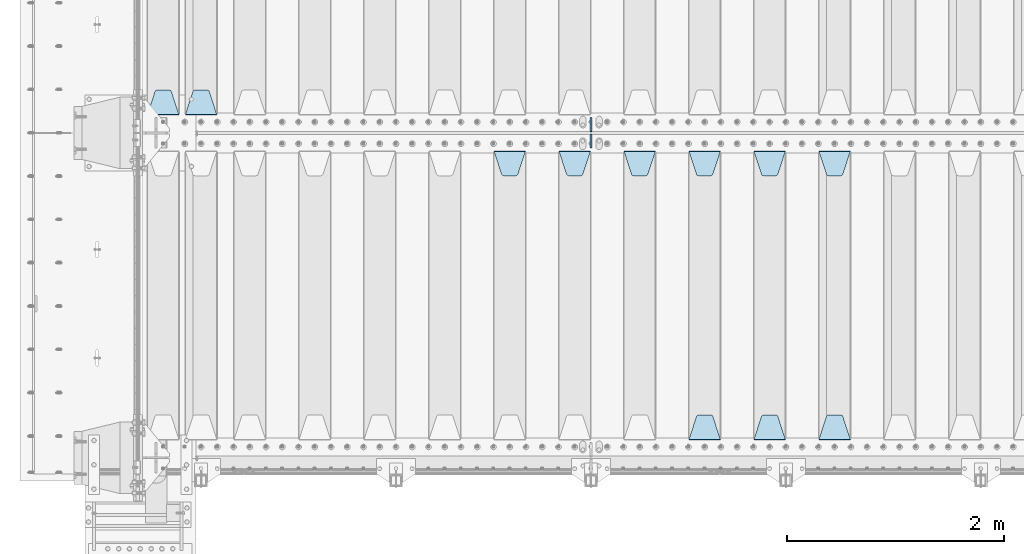
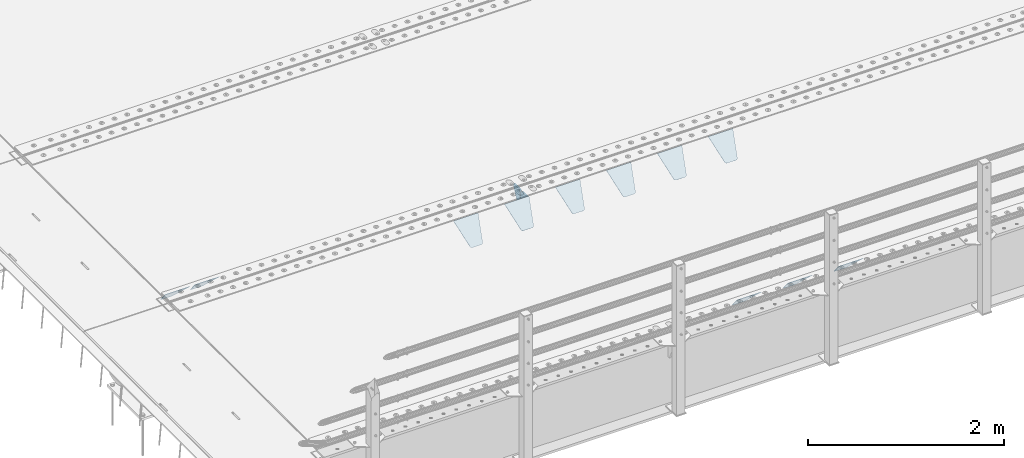
# One storey, part 193 of 240: 13 plates.
"""IFC2X3 building model written with IfcOpenShell, lengths in millimetres."""

from ifc_helpers import new_model, si_unit, frame, origin_with_axes, place, context, subcontext, project, spatial, faceted_brep, material, type_object, element, save


model = new_model("IFC2X3")

# Units and contexts
model_context = context("Model", 3, precision=1e-05, world=origin_with_axes())
body_context = subcontext(model_context, "Body", "Model", "MODEL_VIEW")
ifc_project = project(units=[si_unit("LENGTHUNIT", "METRE", prefix="MILLI"), si_unit("AREAUNIT", "SQUARE_METRE"), si_unit("VOLUMEUNIT", "CUBIC_METRE"), si_unit("MASSUNIT", "GRAM", prefix="KILO"), si_unit("TIMEUNIT", "SECOND"), si_unit("PLANEANGLEUNIT", "RADIAN"), si_unit("SOLIDANGLEUNIT", "STERADIAN"), si_unit("THERMODYNAMICTEMPERATUREUNIT", "DEGREE_CELSIUS"), si_unit("LUMINOUSINTENSITYUNIT", "LUMEN")], contexts=[model_context])

# Site, building, storey
site_placement = place(None, origin_with_axes())
site = spatial("IfcSite", under=ifc_project, at=site_placement, CompositionType="ELEMENT")
building_placement = place(site_placement, origin_with_axes())
building = spatial("IfcBuilding", under=site, at=building_placement, Name="Standard", CompositionType="ELEMENT")
storey_placement = place(building_placement, origin_with_axes())
storey = spatial("IfcBuildingStorey", under=building, at=storey_placement, Name="Undefined", CompositionType="ELEMENT", Elevation=0.0)

# Plates
ifc_material = material(Name="STEEL/S355N")
plate_type_1 = type_object("IfcPlateType", PredefinedType="NOTDEFINED")
plate_1_placement = place(storey_placement, frame((43145.0, 27168.232233047, -1.76776695296758), z_axis=(0.0, 0.707106781186547, -0.707106781186548), x_axis=(-1.0, 0.0, 0.0)))
element("IfcPlate", 1, at=plate_1_placement, inside=storey, type_object=plate_type_1, material=ifc_material, context=body_context, shape_type="Brep", body=[
    faceted_brep([(0.0, -2.5, 0.0), (69.345504679477, -2.50000000000364, 300.171731424827), (69.345504679477, 2.49999999999636, 300.171731424827), (0.0, 2.5, 0.0), (70.927406119954, -2.50000000000364, 304.897442415397), (70.927406119954, 2.49999999999636, 304.897442415397), (73.3818627772271, -2.50000000000728, 309.234538108525), (73.3818627772271, 2.49999999999636, 309.234538108529), (76.6187032999587, -2.50000000000728, 313.023683126099), (76.6187032999587, 2.49999999999636, 313.023683126103), (80.5190132705029, -2.50000000000364, 316.125672595368), (80.5190132705029, 2.49999999999636, 316.125672595368), (84.9395038596849, -2.50000000000364, 318.426546230472), (84.9395038596849, 2.49999999999636, 318.426546230472), (89.7177759439219, -2.5, 319.841774983277), (89.7177759439219, 2.49999999999636, 319.841774983273), (94.6782862926484, -2.50000000000364, 320.319366455074), (94.6782862926484, 2.49999999999636, 320.319366455074), (195.321713707352, -2.50000000000364, 320.319366455074), (195.321713707352, 2.49999999999636, 320.319366455074), (200.282224056078, -2.50000000000364, 319.841774983273), (200.282224056078, 2.49999999999636, 319.841774983273), (205.060496140315, -2.50000000000364, 318.426546230472), (205.060496140315, 2.49999999999636, 318.426546230472), (209.480986729497, -2.50000000000364, 316.125672595368), (209.480986729497, 2.49999999999636, 316.125672595368), (213.381296700041, -2.50000000000728, 313.023683126099), (213.381296700041, 2.49999999999272, 313.023683126099), (216.618137222766, -2.50000000000364, 309.234538108522), (216.618137222766, 2.49999999999636, 309.234538108522), (219.072593880039, -2.50000000000364, 304.897442415397), (219.072593880039, 2.49999999999636, 304.897442415397), (220.654495320523, -2.50000000000364, 300.171731424827), (220.654495320523, 2.49999999999636, 300.171731424827), (290.0, -2.50000000000364, -3.63797880709171e-12), (290.0, 2.49999999999636, -3.63797880709171e-12)], [[[0, 1, 2, 3]], [[1, 4, 5, 2]], [[4, 6, 7, 5]], [[6, 8, 9, 7]], [[8, 10, 11, 9]], [[10, 12, 13, 11]], [[12, 14, 15, 13]], [[14, 16, 17, 15]], [[16, 18, 19, 17]], [[18, 20, 21, 19]], [[20, 22, 23, 21]], [[22, 24, 25, 23]], [[24, 26, 27, 25]], [[26, 28, 29, 27]], [[28, 30, 31, 29]], [[30, 32, 33, 31]], [[32, 34, 35, 33]], [[34, 0, 3, 35]], [[5, 7, 9, 11, 13, 15, 17, 19, 21, 23, 25, 27, 29, 31, 33, 35, 3, 2]], [[34, 32, 30, 28, 26, 24, 22, 20, 18, 16, 14, 12, 10, 8, 6, 4, 1, 0]]]),
])
plate_2_placement = place(storey_placement, frame((48705.0, 26831.767766956, -1.76776695296758), z_axis=(0.0, -0.707106781186547, -0.707106781186548), x_axis=(1.0, 0.0, 0.0)))
element("IfcPlate", 2, at=plate_2_placement, inside=storey, type_object=plate_type_1, material=ifc_material, context=body_context, shape_type="Brep", body=[
    faceted_brep([(0.0, -2.5, 0.0), (69.345504679477, -2.50000000000364, 300.171731424827), (69.345504679477, 2.49999999999636, 300.171731424827), (0.0, 2.5, 0.0), (70.927406119954, -2.50000000000364, 304.897442415397), (70.927406119954, 2.49999999999636, 304.897442415397), (73.3818627772271, -2.50000000000728, 309.234538108525), (73.3818627772271, 2.49999999999636, 309.234538108529), (76.6187032999587, -2.50000000000728, 313.023683126099), (76.6187032999587, 2.49999999999636, 313.023683126103), (80.5190132705029, -2.50000000000364, 316.125672595368), (80.5190132705029, 2.49999999999636, 316.125672595368), (84.9395038596849, -2.50000000000364, 318.426546230472), (84.9395038596849, 2.49999999999636, 318.426546230472), (89.7177759439219, -2.5, 319.841774983277), (89.7177759439219, 2.49999999999636, 319.841774983273), (94.6782862926484, -2.50000000000364, 320.319366455074), (94.6782862926484, 2.49999999999636, 320.319366455074), (195.321713707352, -2.50000000000364, 320.319366455074), (195.321713707352, 2.49999999999636, 320.319366455074), (200.282224056078, -2.50000000000364, 319.841774983273), (200.282224056078, 2.49999999999636, 319.841774983273), (205.060496140315, -2.50000000000364, 318.426546230472), (205.060496140315, 2.49999999999636, 318.426546230472), (209.480986729497, -2.50000000000364, 316.125672595368), (209.480986729497, 2.49999999999636, 316.125672595368), (213.381296700041, -2.50000000000728, 313.023683126099), (213.381296700041, 2.49999999999272, 313.023683126099), (216.618137222766, -2.50000000000364, 309.234538108522), (216.618137222766, 2.49999999999636, 309.234538108522), (219.072593880039, -2.50000000000364, 304.897442415397), (219.072593880039, 2.49999999999636, 304.897442415397), (220.654495320523, -2.50000000000364, 300.171731424827), (220.654495320523, 2.49999999999636, 300.171731424827), (290.0, -2.50000000000364, -3.63797880709171e-12), (290.0, 2.49999999999636, -3.63797880709171e-12)], [[[0, 1, 2, 3]], [[1, 4, 5, 2]], [[4, 6, 7, 5]], [[6, 8, 9, 7]], [[8, 10, 11, 9]], [[10, 12, 13, 11]], [[12, 14, 15, 13]], [[14, 16, 17, 15]], [[16, 18, 19, 17]], [[18, 20, 21, 19]], [[20, 22, 23, 21]], [[22, 24, 25, 23]], [[24, 26, 27, 25]], [[26, 28, 29, 27]], [[28, 30, 31, 29]], [[30, 32, 33, 31]], [[32, 34, 35, 33]], [[34, 0, 3, 35]], [[5, 7, 9, 11, 13, 15, 17, 19, 21, 23, 25, 27, 29, 31, 33, 35, 3, 2]], [[34, 32, 30, 28, 26, 24, 22, 20, 18, 16, 14, 12, 10, 8, 6, 4, 1, 0]]]),
])
plate_3_placement = place(storey_placement, frame((48995.0, 24168.232233047, -1.76776695296758), z_axis=(0.0, 0.707106781186547, -0.707106781186548), x_axis=(-1.0, 0.0, 0.0)))
element("IfcPlate", 3, at=plate_3_placement, inside=storey, type_object=plate_type_1, material=ifc_material, context=body_context, shape_type="Brep", body=[
    faceted_brep([(0.0, -2.5, 0.0), (69.345504679477, -2.50000000000364, 300.171731424827), (69.345504679477, 2.49999999999636, 300.171731424827), (0.0, 2.5, 0.0), (70.927406119954, -2.50000000000364, 304.897442415397), (70.927406119954, 2.49999999999636, 304.897442415397), (73.3818627772271, -2.50000000000728, 309.234538108525), (73.3818627772271, 2.49999999999636, 309.234538108529), (76.6187032999587, -2.50000000000728, 313.023683126099), (76.6187032999587, 2.49999999999636, 313.023683126103), (80.5190132705029, -2.50000000000364, 316.125672595368), (80.5190132705029, 2.49999999999636, 316.125672595368), (84.9395038596849, -2.50000000000364, 318.426546230472), (84.9395038596849, 2.49999999999636, 318.426546230472), (89.7177759439219, -2.5, 319.841774983277), (89.7177759439219, 2.49999999999636, 319.841774983273), (94.6782862926484, -2.50000000000364, 320.319366455074), (94.6782862926484, 2.49999999999636, 320.319366455074), (195.321713707352, -2.50000000000364, 320.319366455074), (195.321713707352, 2.49999999999636, 320.319366455074), (200.282224056078, -2.50000000000364, 319.841774983273), (200.282224056078, 2.49999999999636, 319.841774983273), (205.060496140315, -2.50000000000364, 318.426546230472), (205.060496140315, 2.49999999999636, 318.426546230472), (209.480986729497, -2.50000000000364, 316.125672595368), (209.480986729497, 2.49999999999636, 316.125672595368), (213.381296700041, -2.50000000000728, 313.023683126099), (213.381296700041, 2.49999999999272, 313.023683126099), (216.618137222766, -2.50000000000364, 309.234538108522), (216.618137222766, 2.49999999999636, 309.234538108522), (219.072593880039, -2.50000000000364, 304.897442415397), (219.072593880039, 2.49999999999636, 304.897442415397), (220.654495320523, -2.50000000000364, 300.171731424827), (220.654495320523, 2.49999999999636, 300.171731424827), (290.0, -2.50000000000364, -3.63797880709171e-12), (290.0, 2.49999999999636, -3.63797880709171e-12)], [[[0, 1, 2, 3]], [[1, 4, 5, 2]], [[4, 6, 7, 5]], [[6, 8, 9, 7]], [[8, 10, 11, 9]], [[10, 12, 13, 11]], [[12, 14, 15, 13]], [[14, 16, 17, 15]], [[16, 18, 19, 17]], [[18, 20, 21, 19]], [[20, 22, 23, 21]], [[22, 24, 25, 23]], [[24, 26, 27, 25]], [[26, 28, 29, 27]], [[28, 30, 31, 29]], [[30, 32, 33, 31]], [[32, 34, 35, 33]], [[34, 0, 3, 35]], [[5, 7, 9, 11, 13, 15, 17, 19, 21, 23, 25, 27, 29, 31, 33, 35, 3, 2]], [[34, 32, 30, 28, 26, 24, 22, 20, 18, 16, 14, 12, 10, 8, 6, 4, 1, 0]]]),
])
plate_4_placement = place(storey_placement, frame((48105.0, 26831.767766956, -1.76776695296758), z_axis=(0.0, -0.707106781186547, -0.707106781186548), x_axis=(1.0, 0.0, 0.0)))
element("IfcPlate", 4, at=plate_4_placement, inside=storey, type_object=plate_type_1, material=ifc_material, context=body_context, shape_type="Brep", body=[
    faceted_brep([(0.0, -2.5, 0.0), (69.345504679477, -2.50000000000364, 300.171731424827), (69.345504679477, 2.49999999999636, 300.171731424827), (0.0, 2.5, 0.0), (70.927406119954, -2.50000000000364, 304.897442415397), (70.927406119954, 2.49999999999636, 304.897442415397), (73.3818627772271, -2.50000000000728, 309.234538108525), (73.3818627772271, 2.49999999999636, 309.234538108529), (76.6187032999587, -2.50000000000728, 313.023683126099), (76.6187032999587, 2.49999999999636, 313.023683126103), (80.5190132705029, -2.50000000000364, 316.125672595368), (80.5190132705029, 2.49999999999636, 316.125672595368), (84.9395038596849, -2.50000000000364, 318.426546230472), (84.9395038596849, 2.49999999999636, 318.426546230472), (89.7177759439219, -2.5, 319.841774983277), (89.7177759439219, 2.49999999999636, 319.841774983273), (94.6782862926484, -2.50000000000364, 320.319366455074), (94.6782862926484, 2.49999999999636, 320.319366455074), (195.321713707352, -2.50000000000364, 320.319366455074), (195.321713707352, 2.49999999999636, 320.319366455074), (200.282224056078, -2.50000000000364, 319.841774983273), (200.282224056078, 2.49999999999636, 319.841774983273), (205.060496140315, -2.50000000000364, 318.426546230472), (205.060496140315, 2.49999999999636, 318.426546230472), (209.480986729497, -2.50000000000364, 316.125672595368), (209.480986729497, 2.49999999999636, 316.125672595368), (213.381296700041, -2.50000000000728, 313.023683126099), (213.381296700041, 2.49999999999272, 313.023683126099), (216.618137222766, -2.50000000000364, 309.234538108522), (216.618137222766, 2.49999999999636, 309.234538108522), (219.072593880039, -2.50000000000364, 304.897442415397), (219.072593880039, 2.49999999999636, 304.897442415397), (220.654495320523, -2.50000000000364, 300.171731424827), (220.654495320523, 2.49999999999636, 300.171731424827), (290.0, -2.50000000000364, -3.63797880709171e-12), (290.0, 2.49999999999636, -3.63797880709171e-12)], [[[0, 1, 2, 3]], [[1, 4, 5, 2]], [[4, 6, 7, 5]], [[6, 8, 9, 7]], [[8, 10, 11, 9]], [[10, 12, 13, 11]], [[12, 14, 15, 13]], [[14, 16, 17, 15]], [[16, 18, 19, 17]], [[18, 20, 21, 19]], [[20, 22, 23, 21]], [[22, 24, 25, 23]], [[24, 26, 27, 25]], [[26, 28, 29, 27]], [[28, 30, 31, 29]], [[30, 32, 33, 31]], [[32, 34, 35, 33]], [[34, 0, 3, 35]], [[5, 7, 9, 11, 13, 15, 17, 19, 21, 23, 25, 27, 29, 31, 33, 35, 3, 2]], [[34, 32, 30, 28, 26, 24, 22, 20, 18, 16, 14, 12, 10, 8, 6, 4, 1, 0]]]),
])
plate_5_placement = place(storey_placement, frame((48395.0, 24168.232233047, -1.76776695296758), z_axis=(0.0, 0.707106781186547, -0.707106781186548), x_axis=(-1.0, 0.0, 0.0)))
element("IfcPlate", 5, at=plate_5_placement, inside=storey, type_object=plate_type_1, material=ifc_material, context=body_context, shape_type="Brep", body=[
    faceted_brep([(0.0, -2.5, 0.0), (69.345504679477, -2.50000000000364, 300.171731424827), (69.345504679477, 2.49999999999636, 300.171731424827), (0.0, 2.5, 0.0), (70.927406119954, -2.50000000000364, 304.897442415397), (70.927406119954, 2.49999999999636, 304.897442415397), (73.3818627772271, -2.50000000000728, 309.234538108525), (73.3818627772271, 2.49999999999636, 309.234538108529), (76.6187032999587, -2.50000000000728, 313.023683126099), (76.6187032999587, 2.49999999999636, 313.023683126103), (80.5190132705029, -2.50000000000364, 316.125672595368), (80.5190132705029, 2.49999999999636, 316.125672595368), (84.9395038596849, -2.50000000000364, 318.426546230472), (84.9395038596849, 2.49999999999636, 318.426546230472), (89.7177759439219, -2.5, 319.841774983277), (89.7177759439219, 2.49999999999636, 319.841774983273), (94.6782862926484, -2.50000000000364, 320.319366455074), (94.6782862926484, 2.49999999999636, 320.319366455074), (195.321713707352, -2.50000000000364, 320.319366455074), (195.321713707352, 2.49999999999636, 320.319366455074), (200.282224056078, -2.50000000000364, 319.841774983273), (200.282224056078, 2.49999999999636, 319.841774983273), (205.060496140315, -2.50000000000364, 318.426546230472), (205.060496140315, 2.49999999999636, 318.426546230472), (209.480986729497, -2.50000000000364, 316.125672595368), (209.480986729497, 2.49999999999636, 316.125672595368), (213.381296700041, -2.50000000000728, 313.023683126099), (213.381296700041, 2.49999999999272, 313.023683126099), (216.618137222766, -2.50000000000364, 309.234538108522), (216.618137222766, 2.49999999999636, 309.234538108522), (219.072593880039, -2.50000000000364, 304.897442415397), (219.072593880039, 2.49999999999636, 304.897442415397), (220.654495320523, -2.50000000000364, 300.171731424827), (220.654495320523, 2.49999999999636, 300.171731424827), (290.0, -2.50000000000364, -3.63797880709171e-12), (290.0, 2.49999999999636, -3.63797880709171e-12)], [[[0, 1, 2, 3]], [[1, 4, 5, 2]], [[4, 6, 7, 5]], [[6, 8, 9, 7]], [[8, 10, 11, 9]], [[10, 12, 13, 11]], [[12, 14, 15, 13]], [[14, 16, 17, 15]], [[16, 18, 19, 17]], [[18, 20, 21, 19]], [[20, 22, 23, 21]], [[22, 24, 25, 23]], [[24, 26, 27, 25]], [[26, 28, 29, 27]], [[28, 30, 31, 29]], [[30, 32, 33, 31]], [[32, 34, 35, 33]], [[34, 0, 3, 35]], [[5, 7, 9, 11, 13, 15, 17, 19, 21, 23, 25, 27, 29, 31, 33, 35, 3, 2]], [[34, 32, 30, 28, 26, 24, 22, 20, 18, 16, 14, 12, 10, 8, 6, 4, 1, 0]]]),
])
plate_6_placement = place(storey_placement, frame((47505.0, 26831.767766956, -1.76776695296758), z_axis=(0.0, -0.707106781186547, -0.707106781186548), x_axis=(1.0, 0.0, 0.0)))
element("IfcPlate", 6, at=plate_6_placement, inside=storey, type_object=plate_type_1, material=ifc_material, context=body_context, shape_type="Brep", body=[
    faceted_brep([(0.0, -2.5, 0.0), (69.345504679477, -2.50000000000364, 300.171731424827), (69.345504679477, 2.49999999999636, 300.171731424827), (0.0, 2.5, 0.0), (70.927406119954, -2.50000000000364, 304.897442415397), (70.927406119954, 2.49999999999636, 304.897442415397), (73.3818627772271, -2.50000000000728, 309.234538108525), (73.3818627772271, 2.49999999999636, 309.234538108529), (76.6187032999587, -2.50000000000728, 313.023683126099), (76.6187032999587, 2.49999999999636, 313.023683126103), (80.5190132705029, -2.50000000000364, 316.125672595368), (80.5190132705029, 2.49999999999636, 316.125672595368), (84.9395038596849, -2.50000000000364, 318.426546230472), (84.9395038596849, 2.49999999999636, 318.426546230472), (89.7177759439219, -2.5, 319.841774983277), (89.7177759439219, 2.49999999999636, 319.841774983273), (94.6782862926484, -2.50000000000364, 320.319366455074), (94.6782862926484, 2.49999999999636, 320.319366455074), (195.321713707352, -2.50000000000364, 320.319366455074), (195.321713707352, 2.49999999999636, 320.319366455074), (200.282224056078, -2.50000000000364, 319.841774983273), (200.282224056078, 2.49999999999636, 319.841774983273), (205.060496140315, -2.50000000000364, 318.426546230472), (205.060496140315, 2.49999999999636, 318.426546230472), (209.480986729497, -2.50000000000364, 316.125672595368), (209.480986729497, 2.49999999999636, 316.125672595368), (213.381296700041, -2.50000000000728, 313.023683126099), (213.381296700041, 2.49999999999272, 313.023683126099), (216.618137222766, -2.50000000000364, 309.234538108522), (216.618137222766, 2.49999999999636, 309.234538108522), (219.072593880039, -2.50000000000364, 304.897442415397), (219.072593880039, 2.49999999999636, 304.897442415397), (220.654495320523, -2.50000000000364, 300.171731424827), (220.654495320523, 2.49999999999636, 300.171731424827), (290.0, -2.50000000000364, -3.63797880709171e-12), (290.0, 2.49999999999636, -3.63797880709171e-12)], [[[0, 1, 2, 3]], [[1, 4, 5, 2]], [[4, 6, 7, 5]], [[6, 8, 9, 7]], [[8, 10, 11, 9]], [[10, 12, 13, 11]], [[12, 14, 15, 13]], [[14, 16, 17, 15]], [[16, 18, 19, 17]], [[18, 20, 21, 19]], [[20, 22, 23, 21]], [[22, 24, 25, 23]], [[24, 26, 27, 25]], [[26, 28, 29, 27]], [[28, 30, 31, 29]], [[30, 32, 33, 31]], [[32, 34, 35, 33]], [[34, 0, 3, 35]], [[5, 7, 9, 11, 13, 15, 17, 19, 21, 23, 25, 27, 29, 31, 33, 35, 3, 2]], [[34, 32, 30, 28, 26, 24, 22, 20, 18, 16, 14, 12, 10, 8, 6, 4, 1, 0]]]),
])
plate_7_placement = place(storey_placement, frame((47795.0, 24168.232233047, -1.76776695296758), z_axis=(0.0, 0.707106781186547, -0.707106781186548), x_axis=(-1.0, 0.0, 0.0)))
element("IfcPlate", 7, at=plate_7_placement, inside=storey, type_object=plate_type_1, material=ifc_material, context=body_context, shape_type="Brep", body=[
    faceted_brep([(0.0, -2.5, 0.0), (69.345504679477, -2.50000000000364, 300.171731424827), (69.345504679477, 2.49999999999636, 300.171731424827), (0.0, 2.5, 0.0), (70.927406119954, -2.50000000000364, 304.897442415397), (70.927406119954, 2.49999999999636, 304.897442415397), (73.3818627772271, -2.50000000000728, 309.234538108525), (73.3818627772271, 2.49999999999636, 309.234538108529), (76.6187032999587, -2.50000000000728, 313.023683126099), (76.6187032999587, 2.49999999999636, 313.023683126103), (80.5190132705029, -2.50000000000364, 316.125672595368), (80.5190132705029, 2.49999999999636, 316.125672595368), (84.9395038596849, -2.50000000000364, 318.426546230472), (84.9395038596849, 2.49999999999636, 318.426546230472), (89.7177759439219, -2.5, 319.841774983277), (89.7177759439219, 2.49999999999636, 319.841774983273), (94.6782862926484, -2.50000000000364, 320.319366455074), (94.6782862926484, 2.49999999999636, 320.319366455074), (195.321713707352, -2.50000000000364, 320.319366455074), (195.321713707352, 2.49999999999636, 320.319366455074), (200.282224056078, -2.50000000000364, 319.841774983273), (200.282224056078, 2.49999999999636, 319.841774983273), (205.060496140315, -2.50000000000364, 318.426546230472), (205.060496140315, 2.49999999999636, 318.426546230472), (209.480986729497, -2.50000000000364, 316.125672595368), (209.480986729497, 2.49999999999636, 316.125672595368), (213.381296700041, -2.50000000000728, 313.023683126099), (213.381296700041, 2.49999999999272, 313.023683126099), (216.618137222766, -2.50000000000364, 309.234538108522), (216.618137222766, 2.49999999999636, 309.234538108522), (219.072593880039, -2.50000000000364, 304.897442415397), (219.072593880039, 2.49999999999636, 304.897442415397), (220.654495320523, -2.50000000000364, 300.171731424827), (220.654495320523, 2.49999999999636, 300.171731424827), (290.0, -2.50000000000364, -3.63797880709171e-12), (290.0, 2.49999999999636, -3.63797880709171e-12)], [[[0, 1, 2, 3]], [[1, 4, 5, 2]], [[4, 6, 7, 5]], [[6, 8, 9, 7]], [[8, 10, 11, 9]], [[10, 12, 13, 11]], [[12, 14, 15, 13]], [[14, 16, 17, 15]], [[16, 18, 19, 17]], [[18, 20, 21, 19]], [[20, 22, 23, 21]], [[22, 24, 25, 23]], [[24, 26, 27, 25]], [[26, 28, 29, 27]], [[28, 30, 31, 29]], [[30, 32, 33, 31]], [[32, 34, 35, 33]], [[34, 0, 3, 35]], [[5, 7, 9, 11, 13, 15, 17, 19, 21, 23, 25, 27, 29, 31, 33, 35, 3, 2]], [[34, 32, 30, 28, 26, 24, 22, 20, 18, 16, 14, 12, 10, 8, 6, 4, 1, 0]]]),
])
plate_8_placement = place(storey_placement, frame((46905.0, 26831.767766956, -1.76776695296758), z_axis=(0.0, -0.707106781186547, -0.707106781186548), x_axis=(1.0, 0.0, 0.0)))
element("IfcPlate", 8, at=plate_8_placement, inside=storey, type_object=plate_type_1, material=ifc_material, context=body_context, shape_type="Brep", body=[
    faceted_brep([(0.0, -2.5, 0.0), (69.345504679477, -2.50000000000364, 300.171731424827), (69.345504679477, 2.49999999999636, 300.171731424827), (0.0, 2.5, 0.0), (70.927406119954, -2.50000000000364, 304.897442415397), (70.927406119954, 2.49999999999636, 304.897442415397), (73.3818627772271, -2.50000000000728, 309.234538108525), (73.3818627772271, 2.49999999999636, 309.234538108529), (76.6187032999587, -2.50000000000728, 313.023683126099), (76.6187032999587, 2.49999999999636, 313.023683126103), (80.5190132705029, -2.50000000000364, 316.125672595368), (80.5190132705029, 2.49999999999636, 316.125672595368), (84.9395038596849, -2.50000000000364, 318.426546230472), (84.9395038596849, 2.49999999999636, 318.426546230472), (89.7177759439219, -2.5, 319.841774983277), (89.7177759439219, 2.49999999999636, 319.841774983273), (94.6782862926484, -2.50000000000364, 320.319366455074), (94.6782862926484, 2.49999999999636, 320.319366455074), (195.321713707352, -2.50000000000364, 320.319366455074), (195.321713707352, 2.49999999999636, 320.319366455074), (200.282224056078, -2.50000000000364, 319.841774983273), (200.282224056078, 2.49999999999636, 319.841774983273), (205.060496140315, -2.50000000000364, 318.426546230472), (205.060496140315, 2.49999999999636, 318.426546230472), (209.480986729497, -2.50000000000364, 316.125672595368), (209.480986729497, 2.49999999999636, 316.125672595368), (213.381296700041, -2.50000000000728, 313.023683126099), (213.381296700041, 2.49999999999272, 313.023683126099), (216.618137222766, -2.50000000000364, 309.234538108522), (216.618137222766, 2.49999999999636, 309.234538108522), (219.072593880039, -2.50000000000364, 304.897442415397), (219.072593880039, 2.49999999999636, 304.897442415397), (220.654495320523, -2.50000000000364, 300.171731424827), (220.654495320523, 2.49999999999636, 300.171731424827), (290.0, -2.50000000000364, -3.63797880709171e-12), (290.0, 2.49999999999636, -3.63797880709171e-12)], [[[0, 1, 2, 3]], [[1, 4, 5, 2]], [[4, 6, 7, 5]], [[6, 8, 9, 7]], [[8, 10, 11, 9]], [[10, 12, 13, 11]], [[12, 14, 15, 13]], [[14, 16, 17, 15]], [[16, 18, 19, 17]], [[18, 20, 21, 19]], [[20, 22, 23, 21]], [[22, 24, 25, 23]], [[24, 26, 27, 25]], [[26, 28, 29, 27]], [[28, 30, 31, 29]], [[30, 32, 33, 31]], [[32, 34, 35, 33]], [[34, 0, 3, 35]], [[5, 7, 9, 11, 13, 15, 17, 19, 21, 23, 25, 27, 29, 31, 33, 35, 3, 2]], [[34, 32, 30, 28, 26, 24, 22, 20, 18, 16, 14, 12, 10, 8, 6, 4, 1, 0]]]),
])
plate_9_placement = place(storey_placement, frame((46305.0, 26831.767766956, -1.76776695296758), z_axis=(0.0, -0.707106781186547, -0.707106781186548), x_axis=(1.0, 0.0, 0.0)))
element("IfcPlate", 9, at=plate_9_placement, inside=storey, type_object=plate_type_1, material=ifc_material, context=body_context, shape_type="Brep", body=[
    faceted_brep([(0.0, -2.5, 0.0), (69.345504679477, -2.50000000000364, 300.171731424827), (69.345504679477, 2.49999999999636, 300.171731424827), (0.0, 2.5, 0.0), (70.927406119954, -2.50000000000364, 304.897442415397), (70.927406119954, 2.49999999999636, 304.897442415397), (73.3818627772271, -2.50000000000728, 309.234538108525), (73.3818627772271, 2.49999999999636, 309.234538108529), (76.6187032999587, -2.50000000000728, 313.023683126099), (76.6187032999587, 2.49999999999636, 313.023683126103), (80.5190132705029, -2.50000000000364, 316.125672595368), (80.5190132705029, 2.49999999999636, 316.125672595368), (84.9395038596849, -2.50000000000364, 318.426546230472), (84.9395038596849, 2.49999999999636, 318.426546230472), (89.7177759439219, -2.5, 319.841774983277), (89.7177759439219, 2.49999999999636, 319.841774983273), (94.6782862926484, -2.50000000000364, 320.319366455074), (94.6782862926484, 2.49999999999636, 320.319366455074), (195.321713707352, -2.50000000000364, 320.319366455074), (195.321713707352, 2.49999999999636, 320.319366455074), (200.282224056078, -2.50000000000364, 319.841774983273), (200.282224056078, 2.49999999999636, 319.841774983273), (205.060496140315, -2.50000000000364, 318.426546230472), (205.060496140315, 2.49999999999636, 318.426546230472), (209.480986729497, -2.50000000000364, 316.125672595368), (209.480986729497, 2.49999999999636, 316.125672595368), (213.381296700041, -2.50000000000728, 313.023683126099), (213.381296700041, 2.49999999999272, 313.023683126099), (216.618137222766, -2.50000000000364, 309.234538108522), (216.618137222766, 2.49999999999636, 309.234538108522), (219.072593880039, -2.50000000000364, 304.897442415397), (219.072593880039, 2.49999999999636, 304.897442415397), (220.654495320523, -2.50000000000364, 300.171731424827), (220.654495320523, 2.49999999999636, 300.171731424827), (290.0, -2.50000000000364, -3.63797880709171e-12), (290.0, 2.49999999999636, -3.63797880709171e-12)], [[[0, 1, 2, 3]], [[1, 4, 5, 2]], [[4, 6, 7, 5]], [[6, 8, 9, 7]], [[8, 10, 11, 9]], [[10, 12, 13, 11]], [[12, 14, 15, 13]], [[14, 16, 17, 15]], [[16, 18, 19, 17]], [[18, 20, 21, 19]], [[20, 22, 23, 21]], [[22, 24, 25, 23]], [[24, 26, 27, 25]], [[26, 28, 29, 27]], [[28, 30, 31, 29]], [[30, 32, 33, 31]], [[32, 34, 35, 33]], [[34, 0, 3, 35]], [[5, 7, 9, 11, 13, 15, 17, 19, 21, 23, 25, 27, 29, 31, 33, 35, 3, 2]], [[34, 32, 30, 28, 26, 24, 22, 20, 18, 16, 14, 12, 10, 8, 6, 4, 1, 0]]]),
])
plate_10_placement = place(storey_placement, frame((45705.0, 26831.767766956, -1.76776695296758), z_axis=(0.0, -0.707106781186547, -0.707106781186548), x_axis=(1.0, 0.0, 0.0)))
element("IfcPlate", 10, at=plate_10_placement, inside=storey, type_object=plate_type_1, material=ifc_material, context=body_context, shape_type="Brep", body=[
    faceted_brep([(0.0, -2.5, 0.0), (69.345504679477, -2.50000000000364, 300.171731424827), (69.345504679477, 2.49999999999636, 300.171731424827), (0.0, 2.5, 0.0), (70.927406119954, -2.50000000000364, 304.897442415397), (70.927406119954, 2.49999999999636, 304.897442415397), (73.3818627772271, -2.50000000000728, 309.234538108525), (73.3818627772271, 2.49999999999636, 309.234538108529), (76.6187032999587, -2.50000000000728, 313.023683126099), (76.6187032999587, 2.49999999999636, 313.023683126103), (80.5190132705029, -2.50000000000364, 316.125672595368), (80.5190132705029, 2.49999999999636, 316.125672595368), (84.9395038596849, -2.50000000000364, 318.426546230472), (84.9395038596849, 2.49999999999636, 318.426546230472), (89.7177759439219, -2.5, 319.841774983277), (89.7177759439219, 2.49999999999636, 319.841774983273), (94.6782862926484, -2.50000000000364, 320.319366455074), (94.6782862926484, 2.49999999999636, 320.319366455074), (195.321713707352, -2.50000000000364, 320.319366455074), (195.321713707352, 2.49999999999636, 320.319366455074), (200.282224056078, -2.50000000000364, 319.841774983273), (200.282224056078, 2.49999999999636, 319.841774983273), (205.060496140315, -2.50000000000364, 318.426546230472), (205.060496140315, 2.49999999999636, 318.426546230472), (209.480986729497, -2.50000000000364, 316.125672595368), (209.480986729497, 2.49999999999636, 316.125672595368), (213.381296700041, -2.50000000000728, 313.023683126099), (213.381296700041, 2.49999999999272, 313.023683126099), (216.618137222766, -2.50000000000364, 309.234538108522), (216.618137222766, 2.49999999999636, 309.234538108522), (219.072593880039, -2.50000000000364, 304.897442415397), (219.072593880039, 2.49999999999636, 304.897442415397), (220.654495320523, -2.50000000000364, 300.171731424827), (220.654495320523, 2.49999999999636, 300.171731424827), (290.0, -2.50000000000364, -3.63797880709171e-12), (290.0, 2.49999999999636, -3.63797880709171e-12)], [[[0, 1, 2, 3]], [[1, 4, 5, 2]], [[4, 6, 7, 5]], [[6, 8, 9, 7]], [[8, 10, 11, 9]], [[10, 12, 13, 11]], [[12, 14, 15, 13]], [[14, 16, 17, 15]], [[16, 18, 19, 17]], [[18, 20, 21, 19]], [[20, 22, 23, 21]], [[22, 24, 25, 23]], [[24, 26, 27, 25]], [[26, 28, 29, 27]], [[28, 30, 31, 29]], [[30, 32, 33, 31]], [[32, 34, 35, 33]], [[34, 0, 3, 35]], [[5, 7, 9, 11, 13, 15, 17, 19, 21, 23, 25, 27, 29, 31, 33, 35, 3, 2]], [[34, 32, 30, 28, 26, 24, 22, 20, 18, 16, 14, 12, 10, 8, 6, 4, 1, 0]]]),
])
plate_11_placement = place(storey_placement, frame((42795.0, 27168.232233047, -1.76776695296758), z_axis=(0.0, 0.707106781186547, -0.707106781186548), x_axis=(-1.0, 0.0, 0.0)))
element("IfcPlate", 11, at=plate_11_placement, inside=storey, type_object=plate_type_1, material=ifc_material, context=body_context, shape_type="Brep", body=[
    faceted_brep([(0.0, -2.5, 0.0), (69.345504679477, -2.50000000000364, 300.171731424827), (69.345504679477, 2.49999999999636, 300.171731424827), (0.0, 2.5, 0.0), (70.927406119954, -2.50000000000364, 304.897442415397), (70.927406119954, 2.49999999999636, 304.897442415397), (73.3818627772271, -2.50000000000728, 309.234538108525), (73.3818627772271, 2.49999999999636, 309.234538108529), (76.6187032999587, -2.50000000000728, 313.023683126099), (76.6187032999587, 2.49999999999636, 313.023683126103), (80.5190132705029, -2.50000000000364, 316.125672595368), (80.5190132705029, 2.49999999999636, 316.125672595368), (84.9395038596849, -2.50000000000364, 318.426546230472), (84.9395038596849, 2.49999999999636, 318.426546230472), (89.7177759439219, -2.5, 319.841774983277), (89.7177759439219, 2.49999999999636, 319.841774983273), (94.6782862926484, -2.50000000000364, 320.319366455074), (94.6782862926484, 2.49999999999636, 320.319366455074), (195.321713707352, -2.50000000000364, 320.319366455074), (195.321713707352, 2.49999999999636, 320.319366455074), (200.282224056078, -2.50000000000364, 319.841774983273), (200.282224056078, 2.49999999999636, 319.841774983273), (205.060496140315, -2.50000000000364, 318.426546230472), (205.060496140315, 2.49999999999636, 318.426546230472), (209.480986729497, -2.50000000000364, 316.125672595368), (209.480986729497, 2.49999999999636, 316.125672595368), (213.381296700041, -2.50000000000728, 313.023683126099), (213.381296700041, 2.49999999999272, 313.023683126099), (216.618137222766, -2.50000000000364, 309.234538108522), (216.618137222766, 2.49999999999636, 309.234538108522), (219.072593880039, -2.50000000000364, 304.897442415397), (219.072593880039, 2.49999999999636, 304.897442415397), (220.654495320523, -2.50000000000364, 300.171731424827), (220.654495320523, 2.49999999999636, 300.171731424827), (290.0, -2.50000000000364, -3.63797880709171e-12), (290.0, 2.49999999999636, -3.63797880709171e-12)], [[[0, 1, 2, 3]], [[1, 4, 5, 2]], [[4, 6, 7, 5]], [[6, 8, 9, 7]], [[8, 10, 11, 9]], [[10, 12, 13, 11]], [[12, 14, 15, 13]], [[14, 16, 17, 15]], [[16, 18, 19, 17]], [[18, 20, 21, 19]], [[20, 22, 23, 21]], [[22, 24, 25, 23]], [[24, 26, 27, 25]], [[26, 28, 29, 27]], [[28, 30, 31, 29]], [[30, 32, 33, 31]], [[32, 34, 35, 33]], [[34, 0, 3, 35]], [[5, 7, 9, 11, 13, 15, 17, 19, 21, 23, 25, 27, 29, 31, 33, 35, 3, 2]], [[34, 32, 30, 28, 26, 24, 22, 20, 18, 16, 14, 12, 10, 8, 6, 4, 1, 0]]]),
])
plate_type_2 = type_object("IfcPlateType", PredefinedType="NOTDEFINED")
for number, where, z_axis, x_axis in (
    (12, (46600.0, 26860.0, -30.0), (0.0, 0.0, -1.0), (0.0, 1.0, 0.0)),
    (13, (46600.0, 27140.0, -30.0), (0.0, 0.0, -1.0), (0.0, -1.0, 0.0)),
):
    element("IfcPlate", number, at=place(storey_placement, frame(where, z_axis=z_axis, x_axis=x_axis)), inside=storey, type_object=plate_type_2, material=ifc_material, context=body_context, shape_type="Brep", body=[
        faceted_brep([(0.0, -10.0, 0.0), (0.0, -10.0, 30.0), (0.0, 10.0, 30.0), (0.0, 10.0, 0.0), (102.0, -10.0, 250.0), (102.0, 10.0, 250.0), (132.0, -10.0, 250.0), (132.0, 10.0, 250.0), (132.0, -10.0, 30.0), (132.0, 10.0, 30.0), (131.544232590368, -10.0, 24.790554669992), (131.544232590368, 10.0, 24.790554669992), (130.190778623579, -10.0, 19.7393957002299), (130.190778623579, 10.0, 19.7393957002299), (127.980762113533, -10.0, 15.0), (127.980762113533, 10.0, 15.0), (124.98133329357, -10.0, 10.7163717094038), (124.98133329357, 10.0, 10.7163717094038), (121.283628290596, -10.0, 7.01866670643062), (121.283628290596, 10.0, 7.01866670643062), (117.0, -10.0, 4.01923788646684), (117.0, 10.0, 4.01923788646684), (112.260604299769, -10.0, 1.80922137642278), (112.260604299769, 10.0, 1.80922137642278), (107.209445330009, -10.0, 0.455767409633722), (107.209445330009, 10.0, 0.455767409633722), (102.0, -10.0, 0.0), (102.0, 10.0, 0.0)], [[[0, 1, 2, 3]], [[1, 4, 5, 2]], [[4, 6, 7, 5]], [[6, 8, 9, 7]], [[8, 10, 11, 9]], [[10, 12, 13, 11]], [[12, 14, 15, 13]], [[14, 16, 17, 15]], [[16, 18, 19, 17]], [[18, 20, 21, 19]], [[20, 22, 23, 21]], [[22, 24, 25, 23]], [[24, 26, 27, 25]], [[26, 0, 3, 27]], [[5, 7, 9, 11, 13, 15, 17, 19, 21, 23, 25, 27, 3, 2]], [[26, 24, 22, 20, 18, 16, 14, 12, 10, 8, 6, 4, 1, 0]]]),
    ])

save(model, "model.ifc")
